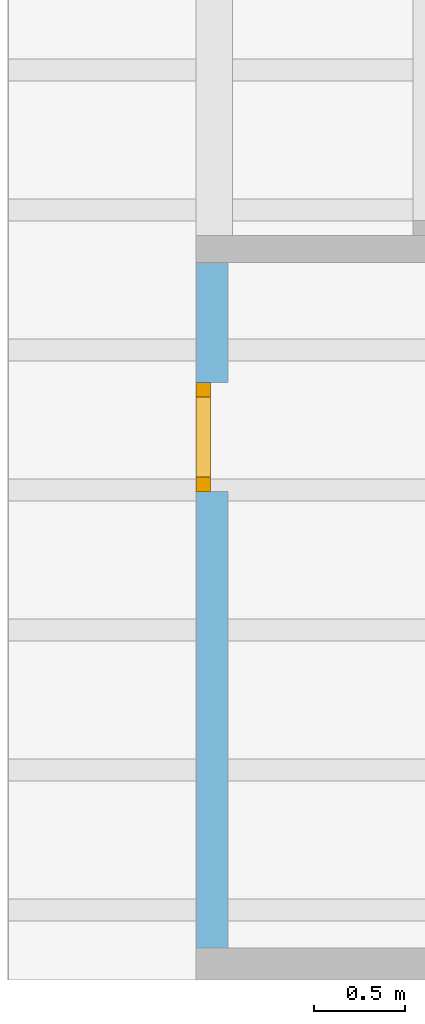
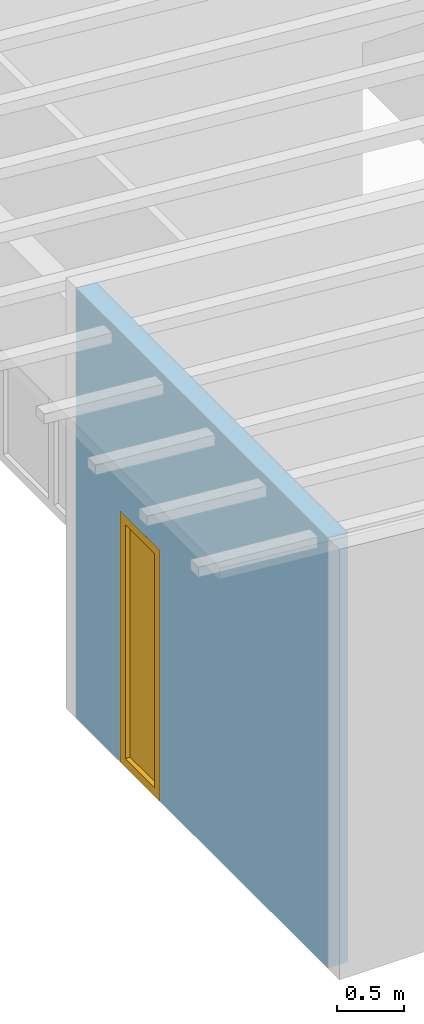
# One storey, part 4 of 13: 1 window, 1 opening, plus 1 element that does not belong to this part.
"""IFC2X3 building model written with IfcOpenShell, lengths in millimetres."""

from ifc_helpers import new_model, entity, si_unit, converted_unit, frame, frame_2d, origin, origin_with_axes, place, context, project, spatial, rectangle, extrude, clip, halfspace, faceted_brep, material, layer, layer_set, layer_usage, element, fill, save


model = new_model("IFC2X3")

# Units and contexts
model_context = context("Model", 3, precision=1e-05, world=origin())
plan_context = context("Plan", 3, precision=1e-05, world=origin())
ifc_project = project(units=[si_unit("LENGTHUNIT", "METRE", prefix="MILLI"), converted_unit("PLANEANGLEUNIT", "DEGREE", entity("IfcPlaneAngleMeasure", 0.0174532925199433), si_unit("PLANEANGLEUNIT", "RADIAN"), dimensions=[0, 0, 0, 0, 0, 0, 0]), si_unit("AREAUNIT", "SQUARE_METRE"), si_unit("VOLUMEUNIT", "CUBIC_METRE")], contexts=[model_context, plan_context])

# Building, storey
building_placement = place(None, origin())
building = spatial("IfcBuilding", under=ifc_project, at=building_placement, CompositionType="ELEMENT")
storey_placement = place(building_placement, frame((0.0, 0.0, 4770.0), z_axis=(0.0, 0.0, 1.0), x_axis=(1.0, 0.0, 0.0)))
storey = spatial("IfcBuildingStorey", under=building, at=storey_placement, Name="Geschoss", CompositionType="ELEMENT", Elevation=4770.0)

# Wall, opening, window
ifc_material_1 = material()
ifc_layer = layer(ifc_material_1, 175.0)
ifc_layer_set = layer_set([ifc_layer])
ifc_layer_usage = layer_usage(ifc_layer_set, "AXIS2", "POSITIVE", 0.0)
wall_placement = place(storey_placement, frame((21188.3517822139, -4741.5625, 0.0), z_axis=(0.0, 0.0, 1.0), x_axis=(0.0, -1.0, 0.0)))
wall = element("IfcWallStandardCase", 1, at=wall_placement, inside=storey, material=ifc_layer_usage, context=model_context, shape_type="Clipping", body=[
    clip(extrude(rectangle(XDim=3775.0, YDim=175.0, at=frame_2d((1887.5, 87.5), x_axis=(1.0, 0.0))), origin_with_axes(), (0.0, 0.0, 1.0), 3940.60829407405), halfspace(frame((0.0, 175.0, 3925.29777795701), z_axis=(0.0, -0.0871557427476597, -0.996194698091745), x_axis=(1.0, 0.0, 0.0)), True)),
])
opening_placement = place(wall_placement, frame((660.000000000001, 0.0, 0.0), z_axis=(0.0, 1.0, 0.0), x_axis=(0.0, 0.0, 1.0)))
opening = element("IfcOpeningElement", 2, at=opening_placement, cuts=wall, ObjectType="Opening", context=model_context, shape_type="SweptSolid", body=[
    extrude(rectangle(XDim=2300.0, YDim=600.0, at=frame_2d((1150.0, 300.0), x_axis=(1.0, 0.0))), origin_with_axes(), (0.0, 0.0, 1.0), 175.0),
])
ifc_material_2 = material()
window_placement = place(opening_placement, frame((0.0, 0.0, 0.0), z_axis=(1.0, 0.0, 0.0), x_axis=(0.0, 1.0, 0.0)))
window = element("IfcWindow", 3, at=window_placement, inside=storey, material=ifc_material_2, Name="m", OverallHeight=2300.0, OverallWidth=600.0, context=model_context, shape_type="Brep", body=[
    faceted_brep([(520.0, 4.3562486951032e-11, 0.0), (520.0, 4.3562486951032e-11, 2300.0), (600.0, 4.35576019697237e-11, 2300.0), (600.0, 4.35576019697237e-11, 0.0), (600.0, 80.0000000000435, 0.0), (600.0, 80.0000000000435, 2300.0), (520.0, 80.0000000000436, 2300.0), (520.0, 80.0000000000436, 0.0), (600.0, 4.35576019697237e-11, 0.0), (600.0, 80.0000000000435, 0.0), (520.0, 80.0000000000436, 0.0), (520.0, 4.3562486951032e-11, 0.0), (600.0, 4.35576019697237e-11, 2300.0), (600.0, 80.0000000000435, 2300.0), (600.0, 80.0000000000435, 0.0), (600.0, 4.35576019697237e-11, 0.0), (520.0, 4.3562486951032e-11, 2300.0), (520.0, 80.0000000000436, 2300.0), (600.0, 80.0000000000435, 2300.0), (600.0, 4.35576019697237e-11, 2300.0), (520.0, 4.3562486951032e-11, 0.0), (520.0, 80.0000000000436, 0.0), (520.0, 80.0000000000436, 2300.0), (520.0, 4.3562486951032e-11, 2300.0)], [[[0, 1, 2, 3]], [[4, 5, 6, 7]], [[8, 9, 10, 11]], [[12, 13, 14, 15]], [[16, 17, 18, 19]], [[20, 21, 22, 23]]], orient=[[False], [False], [False], [False], [False], [False]]),
    faceted_brep([(80.0, 4.36036762252456e-11, 2300.0), (80.0, 4.36036762252456e-11, 0.0), (-3.67381906139166e-17, 4.3608561206554e-11, 0.0), (-3.67381906139166e-17, 4.3608561206554e-11, 2300.0), (4.86168722467559e-15, 80.0000000000436, 2300.0), (4.86168722467559e-15, 80.0000000000436, 0.0), (80.0, 80.0000000000436, 0.0), (80.0, 80.0000000000436, 2300.0), (-3.67381906139166e-17, 4.3608561206554e-11, 2300.0), (4.86168722467559e-15, 80.0000000000436, 2300.0), (80.0, 80.0000000000436, 2300.0), (80.0, 4.36036762252456e-11, 2300.0), (-3.67381906139166e-17, 4.3608561206554e-11, 0.0), (4.86168722467559e-15, 80.0000000000436, 0.0), (4.86168722467559e-15, 80.0000000000436, 2300.0), (-3.67381906139166e-17, 4.3608561206554e-11, 2300.0), (80.0, 4.36036762252456e-11, 0.0), (80.0, 80.0000000000436, 0.0), (4.86168722467559e-15, 80.0000000000436, 0.0), (-3.67381906139166e-17, 4.3608561206554e-11, 0.0), (80.0, 4.36036762252456e-11, 2300.0), (80.0, 80.0000000000436, 2300.0), (80.0, 80.0000000000436, 0.0), (80.0, 4.36036762252456e-11, 0.0)], [[[0, 1, 2, 3]], [[4, 5, 6, 7]], [[8, 9, 10, 11]], [[12, 13, 14, 15]], [[16, 17, 18, 19]], [[20, 21, 22, 23]]], orient=[[False], [False], [False], [False], [False], [False]]),
    faceted_brep([(520.0, 4.35944613741412e-11, 2220.0), (80.0, 4.36214397936396e-11, 2220.0), (80.0, 4.36214397936396e-11, 2300.0), (520.0, 4.35944613741412e-11, 2300.0), (520.0, 80.0000000000436, 2300.0), (80.0, 80.0000000000436, 2300.0), (80.0, 80.0000000000436, 2220.0), (520.0, 80.0000000000436, 2220.0), (520.0, 4.35944613741412e-11, 2300.0), (520.0, 80.0000000000436, 2300.0), (520.0, 80.0000000000436, 2220.0), (520.0, 4.35944613741412e-11, 2220.0), (80.0, 4.36214397936396e-11, 2300.0), (80.0, 80.0000000000436, 2300.0), (520.0, 80.0000000000436, 2300.0), (520.0, 4.35944613741412e-11, 2300.0), (80.0, 4.36214397936396e-11, 2220.0), (80.0, 80.0000000000436, 2220.0), (80.0, 80.0000000000436, 2300.0), (80.0, 4.36214397936396e-11, 2300.0), (520.0, 4.35944613741412e-11, 2220.0), (520.0, 80.0000000000436, 2220.0), (80.0, 80.0000000000436, 2220.0), (80.0, 4.36214397936396e-11, 2220.0)], [[[0, 1, 2, 3]], [[4, 5, 6, 7]], [[8, 9, 10, 11]], [[12, 13, 14, 15]], [[16, 17, 18, 19]], [[20, 21, 22, 23]]], orient=[[False], [False], [False], [False], [False], [False]]),
    faceted_brep([(80.0, 4.36214397936396e-11, 80.0), (520.0, 4.35944613741412e-11, 80.0), (520.0, 4.35944613741412e-11, 0.0), (80.0, 4.36214397936396e-11, 0.0), (80.0, 80.0000000000436, 0.0), (520.0, 80.0000000000436, 0.0), (520.0, 80.0000000000436, 80.0), (80.0, 80.0000000000436, 80.0), (80.0, 4.36214397936396e-11, 0.0), (80.0, 80.0000000000436, 0.0), (80.0, 80.0000000000436, 80.0), (80.0, 4.36214397936396e-11, 80.0), (520.0, 4.35944613741412e-11, 0.0), (520.0, 80.0000000000436, 0.0), (80.0, 80.0000000000436, 0.0), (80.0, 4.36214397936396e-11, 0.0), (520.0, 4.35944613741412e-11, 80.0), (520.0, 80.0000000000436, 80.0), (520.0, 80.0000000000436, 0.0), (520.0, 4.35944613741412e-11, 0.0), (80.0, 4.36214397936396e-11, 80.0), (80.0, 80.0000000000436, 80.0), (520.0, 80.0000000000436, 80.0), (520.0, 4.35944613741412e-11, 80.0)], [[[0, 1, 2, 3]], [[4, 5, 6, 7]], [[8, 9, 10, 11]], [[12, 13, 14, 15]], [[16, 17, 18, 19]], [[20, 21, 22, 23]]], orient=[[False], [False], [False], [False], [False], [False]]),
    faceted_brep([(520.0, 40.0000000000436, 80.0), (80.0, 40.0000000000436, 80.0), (80.0, 40.0000000000436, 2220.0), (520.0, 40.0000000000436, 2220.0), (520.0, 41.0000000000436, 80.0), (520.0, 41.0000000000436, 2220.0), (80.0, 41.0000000000436, 2220.0), (80.0, 41.0000000000436, 80.0), (520.0, 40.0000000000436, 80.0), (520.0, 41.0000000000436, 80.0), (80.0, 41.0000000000436, 80.0), (80.0, 40.0000000000436, 80.0), (80.0, 40.0000000000436, 80.0), (80.0, 41.0000000000436, 80.0), (80.0, 41.0000000000436, 2220.0), (80.0, 40.0000000000436, 2220.0), (80.0, 40.0000000000436, 2220.0), (80.0, 41.0000000000436, 2220.0), (520.0, 41.0000000000436, 2220.0), (520.0, 40.0000000000436, 2220.0), (520.0, 40.0000000000436, 2220.0), (520.0, 41.0000000000436, 2220.0), (520.0, 41.0000000000436, 80.0), (520.0, 40.0000000000436, 80.0)], [[[0, 1, 2, 3]], [[4, 5, 6, 7]], [[8, 9, 10, 11]], [[12, 13, 14, 15]], [[16, 17, 18, 19]], [[20, 21, 22, 23]]], orient=[[False], [False], [False], [False], [False], [False]]),
])
fill(opening, window)

save(model, "model.ifc")
